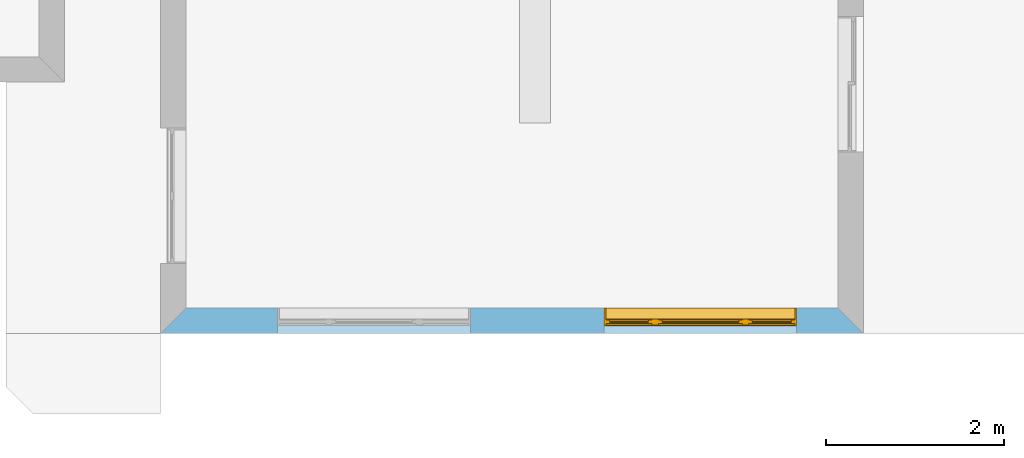
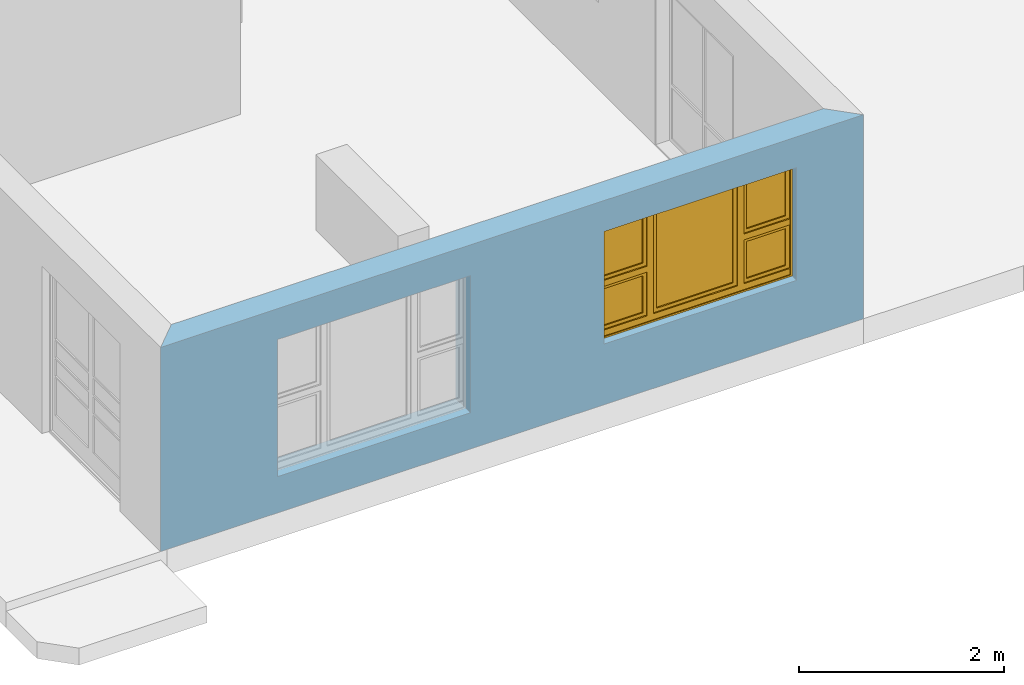
# One storey, part 5 of 15: 1 window, 2 openings, plus 1 element that does not belong to this part.
"""IFC4 building model written with IfcOpenShell, lengths in millimetres."""

from ifc_helpers import new_model, entity, si_unit, converted_unit, frame, origin_with_axes, origin_2d_with_axis, place, context, subcontext, project, spatial, line, indexed_curve, outline, extrude, clip, halfspace, polygons, source, transform, mapped, material, layer, layer_set, layer_usage, type_object, type_shapes, element, fill, save


model = new_model("IFC4")

# Units and contexts
model_context = context("Model", 3, precision=1e-05, world=origin_with_axes())
plan_context = context("Plan", 2, precision=1e-05, world=origin_2d_with_axis())
body_context = subcontext(model_context, "Body", "Model", "MODEL_VIEW")
ifc_project = project(units=[si_unit("VOLUMEUNIT", "CUBIC_METRE"), si_unit("LENGTHUNIT", "METRE", prefix="MILLI"), converted_unit("PLANEANGLEUNIT", "degree", entity("IfcReal", 0.0174532925199433), si_unit("PLANEANGLEUNIT", "RADIAN"), dimensions=[0, 0, 0, 0, 0, 0, 0]), si_unit("AREAUNIT", "SQUARE_METRE")], contexts=[model_context, plan_context])

# Site, building, storey
site_placement = place(None, origin_with_axes())
site = spatial("IfcSite", under=ifc_project, at=site_placement)
building_placement = place(site_placement, origin_with_axes())
building = spatial("IfcBuilding", under=site, at=building_placement, Name="Building")
storey_placement = place(building_placement, origin_with_axes())
storey = spatial("IfcBuildingStorey", under=building, at=storey_placement, Name="EXISTING")

# Wall, openings, window
ifc_material = material()
ifc_layer = layer(ifc_material, 285.0, Name="brick")
ifc_layer_set = layer_set([ifc_layer])
ifc_layer_usage = layer_usage(ifc_layer_set, "AXIS2", "POSITIVE", 0.0)
wall_type = type_object("IfcWallType", Name="285mm Wall", PredefinedType="STANDARD", material=ifc_layer_set)
wall_placement = place(storey_placement, frame((5594.11907196045, -4518.33248138428, 0.0), z_axis=(0.0, 0.0, 1.0), x_axis=(0.999999999999993, 1.19209282445353e-07, 0.0)))
wall = element("IfcWall", 1, at=wall_placement, inside=storey, type_object=wall_type, material=ifc_layer_usage, Name="Wall", context=body_context, shape_type="Clipping", body=[
    clip(clip(extrude(outline(indexed_curve([(0.0, 0.0), (0.0, 285.0), (7900.00095608862, 285.0), (7900.00095608862, 0.0), (0.0, 0.0)], self_intersect=False)), origin_with_axes(), (0.0, 0.0, 1.0), 2425.00019073486), halfspace(frame((7900.00104904175, 0.0, 0.0), z_axis=(0.707107067108154, 0.707106471061707, 0.0), x_axis=(0.707106483163256, -0.707107079209714, 0.0)), False)), halfspace(frame((0.0, 0.0, 0.0), z_axis=(-0.707106471061707, 0.707107067108154, 0.0), x_axis=(0.707107079209714, 0.707106483163256, 0.0)), False)),
])
shared_shape_1 = source(origin_with_axes(), body_context, "Body", "SweptSolid", [
    extrude(outline(indexed_curve([(0.0, 0.0), (2165.00024414062, 0.0), (2165.00024414062, 1629.99987792969), (0.0, 1629.99987792969)], segments=[line(1, 2, 3, 4, 1)])), frame((-1.04308121251506e-07, -600.0, 0.0), z_axis=(0.0, -1.0, 0.0), x_axis=(1.0, 0.0, 0.0)), (0.0, 0.0, -1.0), 1200.0),
])
opening_1_placement = place(wall_placement, frame((3482.00082778931, 136.111021041866, 430.000007152557), z_axis=(0.0, 0.0, 1.0), x_axis=(-0.999999999999989, 1.50995802528085e-07, 0.0)))
element("IfcOpeningElement", 2, at=opening_1_placement, cuts=wall, Name="Opening", PredefinedType="OPENING", context=body_context, shape_type="MappedRepresentation", body=[
    mapped(shared_shape_1, transform((0.0, 0.0, 0.0), x_axis=(1.0, 0.0, 0.0), y_axis=(0.0, 1.0, 0.0), z_axis=(0.0, 0.0, 1.0), scale=1.0)),
])
shared_shape_2 = source(origin_with_axes(), body_context, "Body", "SweptSolid", [
    extrude(outline(indexed_curve([(0.0, 0.0), (2165.00048828125, 0.0), (2165.00048828125, 1340.00048828125), (0.0, 1340.00048828125)], segments=[line(1, 2, 3, 4, 1)])), frame((-5.96046390910487e-07, -600.0, 0.0), z_axis=(0.0, -1.0, 0.0), x_axis=(1.0, 0.0, 0.0)), (0.0, 0.0, -1.0), 1200.0),
])
opening_2_placement = place(wall_placement, frame((7150.00581741333, 136.111021041866, 719.999313354492), z_axis=(0.0, 0.0, 1.0), x_axis=(-0.999999999999989, 1.50995802528085e-07, 0.0)))
opening_2 = element("IfcOpeningElement", 3, at=opening_2_placement, cuts=wall, PredefinedType="OPENING", context=body_context, shape_type="MappedRepresentation", body=[
    mapped(shared_shape_2, transform((0.0, 0.0, 0.0), x_axis=(1.0, 0.0, 0.0), y_axis=(0.0, 1.0, 0.0), z_axis=(0.0, 0.0, 1.0), scale=1.0)),
])
window_type = type_object("IfcWindowType", Name="Ex.2165x1340", PartitioningType="NOTDEFINED", PredefinedType="WINDOW")
shared_shape_3 = source(origin_with_axes(), body_context, "Body", "Tessellation", [
    polygons([(2165.00024414062, -148.888916015625, 0.0), (2165.00024414062, -148.888916015625, 19.999979019165), (0.000119209282274824, -148.888977050781, 0.0), (0.000119209282274824, -148.888977050781, 19.999979019165), (2165.00024414062, 51.1110572814941, 0.0), (2165.00024414062, 51.1110572814941, 19.999979019165), (0.000119209282274824, 51.1110000610352, 0.0), (0.000119209282274824, 51.1110000610352, 19.999979019165), (2165.00024414062, -148.888916015625, 1320.00048828125), (2165.00024414062, -148.888916015625, 1340.00048828125), (0.000119209282274824, -148.888977050781, 1320.00048828125), (0.000119209282274824, -148.888977050781, 1340.00048828125), (2165.00024414062, 51.1110572814941, 1320.00048828125), (2165.00024414062, 51.1110572814941, 1340.00048828125), (0.000119209282274824, 51.1110000610352, 1320.00048828125), (0.000119209282274824, 51.1110000610352, 1340.00048828125), (0.000119209282274824, -148.888916015625, 19.9999198913574), (19.9998607635498, -148.888916015625, 19.9999198913574), (-0.000357627839548513, -148.888977050781, 1340.00036621094), (19.9996223449707, -148.888977050781, 1340.00036621094), (0.000119209282274824, 51.1110572814941, 19.9999198913574), (19.9998607635498, 51.1110572814941, 19.9999198913574), (-0.000596046389546245, 51.1110000610352, 1340.00036621094), (19.9996223449707, 51.1110000610352, 1340.00036621094), (2145.00024414062, -148.888916015625, 19.9999198913574), (2165.00024414062, -148.888916015625, 19.9999198913574), (2144.99975585938, -148.888977050781, 1340.00036621094), (2164.99975585938, -148.888977050781, 1340.00036621094), (2145.00024414062, 51.1110572814941, 19.9999198913574), (2165.00024414062, 51.1110572814941, 19.9999198913574), (2144.99975585938, 51.1110000610352, 1340.00036621094), (2164.99975585938, 51.1110000610352, 1340.00036621094), (1554.99975585938, -28.8889198303223, 19.9999198913574), (1624.99987792969, -28.8889198303223, 19.9999198913574), (1554.99951171875, -28.8889198303223, 1340.00048828125), (1624.99938964844, -28.8889198303223, 1340.00048828125), (1554.99975585938, 41.1110687255859, 19.9999198913574), (1624.99987792969, 41.1110687255859, 19.9999198913574), (1554.99951171875, 41.1110076904297, 1340.00048828125), (1624.99938964844, 41.1110687255859, 1340.00048828125), (539.999938964844, -28.8889198303223, 19.9999198913574), (609.999633789062, -28.8889198303223, 19.9999198913574), (539.999450683594, -28.8889198303223, 1340.00048828125), (609.999633789062, -28.8889198303223, 1340.00048828125), (539.999938964844, 41.1110687255859, 19.9999198913574), (609.999633789062, 41.1110687255859, 19.9999198913574), (539.999450683594, 41.1110076904297, 1340.00048828125), (609.999633789062, 41.1110687255859, 1340.00048828125), (19.9998607635498, -28.8889808654785, 679.999328613281), (19.9998607635498, -28.8889808654785, 609.999877929688), (539.999938964844, -28.8889198303223, 680.0), (539.999938964844, -28.8888607025146, 610.000671386719), (19.9998607635498, 41.1109504699707, 679.999328613281), (19.9998607635498, 41.1110076904297, 609.999877929688), (539.999938964844, 41.1110687255859, 680.0), (539.999938964844, 41.1110687255859, 610.000671386719), (1624.99987792969, -28.8889808654785, 679.999328613281), (1624.99987792969, -28.8889808654785, 609.999877929688), (2144.99975585938, -28.8889198303223, 680.0), (2144.99975585938, -28.8888607025146, 610.000671386719), (1624.99987792969, 41.1109504699707, 679.999328613281), (1624.99987792969, 41.1110076904297, 609.999877929688), (2144.99975585938, 41.1110687255859, 680.0), (2144.99975585938, 41.1110687255859, 610.000671386719), (1624.99987792969, -13.8889951705933, 1319.99987792969), (1624.99987792969, -13.8889951705933, 1280.00024414062), (2144.99975585938, -13.8889360427856, 1320.00048828125), (2144.99975585938, -13.8889360427856, 1280.00073242188), (1624.99987792969, 26.1109638214111, 1319.99987792969), (1624.99987792969, 26.1109638214111, 1280.00024414062), (2144.99975585938, 26.111083984375, 1320.00048828125), (2144.99975585938, 26.111083984375, 1280.00073242188), (1624.99987792969, -13.8889951705933, 719.9990234375), (1624.99987792969, -13.8889951705933, 679.999328613281), (2144.99975585938, -13.8889360427856, 719.99951171875), (2144.99975585938, -13.8889360427856, 679.999816894531), (1624.99987792969, 26.1109638214111, 719.9990234375), (1624.99987792969, 26.1109638214111, 679.999328613281), (2144.99975585938, 26.111083984375, 719.99951171875), (2144.99975585938, 26.111083984375, 679.999816894531), (1664.99987792969, -13.8889360427856, 1280.00024414062), (1624.99987792969, -13.8889360427856, 1280.00024414062), (1664.99987792969, -13.8889360427856, 719.998779296875), (1624.99987792969, -13.8889360427856, 719.998779296875), (1664.99987792969, 26.111083984375, 1280.00024414062), (1624.99987792969, 26.111083984375, 1280.00024414062), (1664.99987792969, 26.111083984375, 719.998779296875), (1624.99987792969, 26.111083984375, 719.998779296875), (2144.99926757812, -13.8889360427856, 1280.00024414062), (2105.0, -13.8889360427856, 1280.00024414062), (2144.99877929688, -13.8889360427856, 719.998779296875), (2104.99951171875, -13.8889360427856, 719.998779296875), (2144.99926757812, 26.111083984375, 1280.00024414062), (2105.0, 26.111083984375, 1280.00024414062), (2144.99877929688, 26.111083984375, 719.998779296875), (2104.99951171875, 26.111083984375, 719.998779296875), (19.9998607635498, -13.8889951705933, 1319.99987792969), (19.9998607635498, -13.8889951705933, 1280.00024414062), (539.999938964844, -13.8889360427856, 1320.00048828125), (539.999938964844, -13.8889360427856, 1280.00073242188), (19.9998607635498, 26.1109638214111, 1319.99987792969), (19.9998607635498, 26.1109638214111, 1280.00024414062), (539.999938964844, 26.111083984375, 1320.00048828125), (539.999938964844, 26.111083984375, 1280.00073242188), (19.9998607635498, -13.8889951705933, 719.9990234375), (19.9998607635498, -13.8889951705933, 679.999328613281), (539.999938964844, -13.8889360427856, 719.99951171875), (539.999938964844, -13.8889360427856, 679.999816894531), (19.9998607635498, 26.1109638214111, 719.9990234375), (19.9998607635498, 26.1109638214111, 679.999328613281), (539.999938964844, 26.111083984375, 719.99951171875), (539.999938964844, 26.111083984375, 679.999816894531), (60.0002975463867, -13.8889360427856, 1280.00024414062), (20.000337600708, -13.8889360427856, 1280.00024414062), (59.9998207092285, -13.8889360427856, 719.998779296875), (20.000337600708, -13.8889360427856, 719.998779296875), (60.0002975463867, 26.111083984375, 1280.00024414062), (20.000337600708, 26.111083984375, 1280.00024414062), (59.9998207092285, 26.111083984375, 719.998779296875), (20.000337600708, 26.111083984375, 719.998779296875), (539.999450683594, -13.8889360427856, 1280.00024414062), (499.999603271484, -13.8889360427856, 1280.00024414062), (539.999450683594, -13.8889360427856, 719.998779296875), (499.999603271484, -13.8889360427856, 719.998779296875), (539.999450683594, 26.111083984375, 1280.00024414062), (499.999603271484, 26.111083984375, 1280.00024414062), (539.999450683594, 26.111083984375, 719.998779296875), (499.999603271484, 26.111083984375, 719.998779296875), (19.9998607635498, -28.8889808654785, 89.9991912841797), (19.9998607635498, -28.8889808654785, 19.9998016357422), (539.999938964844, -28.8889198303223, 89.9999694824219), (539.999938964844, -28.8888607025146, 20.0005760192871), (19.9998607635498, 41.1109504699707, 89.9991912841797), (19.9998607635498, 41.1110076904297, 19.9998016357422), (539.999938964844, 41.1110687255859, 90.0000305175781), (539.999938964844, 41.1110687255859, 20.0005760192871), (1624.99987792969, -28.8889808654785, 89.9991912841797), (1624.99987792969, -28.8889808654785, 19.9998016357422), (2144.99975585938, -28.8889198303223, 89.9999694824219), (2144.99975585938, -28.8888607025146, 20.0005760192871), (1624.99987792969, 41.1109504699707, 89.9991912841797), (1624.99987792969, 41.1110076904297, 19.9998016357422), (2144.99975585938, 41.1110687255859, 90.0000305175781), (2144.99975585938, 41.1110687255859, 20.0005760192871), (610.000122070312, -28.8889808654785, 89.9991912841797), (610.000122070312, -28.8889808654785, 19.9998016357422), (1554.99975585938, -28.8889198303223, 89.9999694824219), (1554.99975585938, -28.8889198303223, 20.0005760192871), (610.000122070312, 41.1109504699707, 89.9991912841797), (610.000122070312, 41.1110076904297, 19.9998016357422), (1554.99975585938, 41.1110687255859, 90.0000305175781), (1554.99975585938, 41.1110687255859, 20.0005760192871), (1624.99987792969, -13.8889951705933, 610.0), (1624.99987792969, -13.8889951705933, 570.000366210938), (2144.99975585938, -13.8889360427856, 610.000549316406), (2144.99975585938, -13.8889360427856, 570.000854492188), (1624.99987792969, 26.1109638214111, 610.0), (1624.99987792969, 26.1109638214111, 570.000366210938), (2144.99975585938, 26.111083984375, 610.000549316406), (2144.99975585938, 26.111083984375, 570.000854492188), (1624.99987792969, -13.8889951705933, 129.999694824219), (1624.99987792969, -13.8889951705933, 90.0000305175781), (2144.99975585938, -13.8889360427856, 130.000228881836), (2144.99975585938, -13.8889360427856, 90.0005645751953), (1624.99987792969, 26.1109638214111, 129.999755859375), (1624.99987792969, 26.1109638214111, 90.0000305175781), (2144.99975585938, 26.111083984375, 130.000228881836), (2144.99975585938, 26.111083984375, 90.0005645751953), (1664.99987792969, -13.8889360427856, 570.000366210938), (1624.99987792969, -13.8889360427856, 570.000366210938), (1664.99987792969, -13.8889360427856, 129.999099731445), (1624.99987792969, -13.8889360427856, 129.999145507812), (1664.99987792969, 26.111083984375, 570.000366210938), (1624.99987792969, 26.111083984375, 570.000366210938), (1664.99987792969, 26.111083984375, 129.999099731445), (1624.99987792969, 26.111083984375, 129.999145507812), (2144.99926757812, -13.8889360427856, 570.000366210938), (2105.0, -13.8889360427856, 570.000366210938), (2144.99877929688, -13.8889360427856, 129.999099731445), (2104.99951171875, -13.8889360427856, 129.999145507812), (2144.99926757812, 26.111083984375, 570.000366210938), (2105.0, 26.111083984375, 570.000366210938), (2144.99877929688, 26.111083984375, 129.999099731445), (2104.99951171875, 26.111083984375, 129.999145507812), (19.9998607635498, -13.8889951705933, 610.0), (19.9998607635498, -13.8889951705933, 570.000366210938), (539.999938964844, -13.8889360427856, 610.000549316406), (539.999938964844, -13.8889360427856, 570.000854492188), (19.9998607635498, 26.1109638214111, 610.0), (19.9998607635498, 26.1109638214111, 570.000366210938), (539.999938964844, 26.111083984375, 610.000549316406), (539.999938964844, 26.111083984375, 570.000854492188), (19.9998607635498, -13.8889951705933, 129.998611450195), (19.9998607635498, -13.8889951705933, 89.9989547729492), (539.999938964844, -13.8889360427856, 129.999145507812), (539.999938964844, -13.8889360427856, 89.9994888305664), (19.9998607635498, 26.1109638214111, 129.998672485352), (19.9998607635498, 26.1109638214111, 89.9989547729492), (539.999938964844, 26.111083984375, 129.999145507812), (539.999938964844, 26.111083984375, 89.9994888305664), (60.0002975463867, -13.8889360427856, 570.000366210938), (20.000337600708, -13.8889360427856, 570.000366210938), (59.9998207092285, -13.8889360427856, 129.999099731445), (20.000337600708, -13.8889360427856, 129.999145507812), (60.0002975463867, 26.111083984375, 570.000366210938), (20.000337600708, 26.111083984375, 570.000366210938), (59.9998207092285, 26.111083984375, 129.999099731445), (20.000337600708, 26.111083984375, 129.999145507812), (539.999450683594, -13.8889360427856, 570.000366210938), (499.999603271484, -13.8889360427856, 570.000366210938), (539.999450683594, -13.8889360427856, 129.999099731445), (499.999603271484, -13.8889360427856, 129.999145507812), (539.999450683594, 26.111083984375, 570.000366210938), (499.999603271484, 26.111083984375, 570.000366210938), (539.999450683594, 26.111083984375, 129.999099731445), (499.999603271484, 26.111083984375, 129.999145507812), (610.000122070312, -13.8889951705933, 1319.99987792969), (610.000122070312, -13.8889951705933, 1280.00024414062), (1554.99951171875, -13.8889360427856, 1320.00048828125), (1554.99951171875, -13.8889360427856, 1280.00073242188), (610.000122070312, 26.1109638214111, 1319.99987792969), (610.000122070312, 26.1109638214111, 1280.00024414062), (1554.99951171875, 26.111083984375, 1320.00048828125), (1554.99951171875, 26.111083984375, 1280.00073242188), (610.000122070312, -13.8889951705933, 129.998916625977), (610.000122070312, -13.8889951705933, 89.9992523193359), (1554.99951171875, -13.8889360427856, 129.999450683594), (1554.99951171875, -13.8889360427856, 89.9997863769531), (610.000122070312, 26.1109638214111, 129.998916625977), (610.000122070312, 26.1109638214111, 89.9992523193359), (1554.99951171875, 26.111083984375, 129.99951171875), (1554.99951171875, 26.111083984375, 89.9997863769531), (650.000549316406, -13.8889360427856, 1280.00024414062), (610.000549316406, -13.8889360427856, 1280.00024414062), (650.000061035156, -13.8889360427856, 129.999450683594), (610.000549316406, -13.8889360427856, 129.999450683594), (650.000549316406, 26.111083984375, 1280.00024414062), (610.000549316406, 26.111083984375, 1280.00024414062), (650.000061035156, 26.111083984375, 129.999450683594), (610.000549316406, 26.111083984375, 129.999450683594), (1554.99975585938, -13.8889360427856, 1280.00024414062), (1514.99975585938, -13.8889360427856, 1280.00024414062), (1554.99926757812, -13.8889360427856, 129.999389648438), (1514.99975585938, -13.8889360427856, 129.999389648438), (1554.99975585938, 26.111083984375, 1280.00024414062), (1514.99975585938, 26.111083984375, 1280.00024414062), (1554.99951171875, 26.111083984375, 129.999389648438), (1514.99975585938, 26.111083984375, 129.999389648438), (1515.00024414062, 1.11104917526245, 1280.00024414062), (650.001037597656, 1.11104917526245, 1280.00024414062), (1514.99975585938, 1.11104917526245, 129.999389648438), (650.001037597656, 1.11104917526245, 129.999450683594), (1515.00024414062, 11.1110391616821, 1280.00024414062), (650.001037597656, 11.1110982894897, 1280.00024414062), (1514.99975585938, 11.1110391616821, 129.999389648438), (650.001037597656, 11.1110982894897, 129.999450683594), (2104.99853515625, 1.11104917526245, 1280.00024414062), (1664.99963378906, 1.11104917526245, 1280.00036621094), (2104.998046875, 1.11104917526245, 719.999267578125), (1664.99938964844, 1.11104917526245, 719.999267578125), (2104.99853515625, 11.1110391616821, 1280.00024414062), (1664.99963378906, 11.1110982894897, 1280.00036621094), (2104.998046875, 11.1110391616821, 719.999267578125), (1664.99938964844, 11.1110982894897, 719.999267578125), (2104.99853515625, 1.11104917526245, 570.000244140625), (1664.99963378906, 1.11104917526245, 570.000244140625), (2104.998046875, 1.11104917526245, 130.000579833984), (1664.99938964844, 1.11104917526245, 130.000579833984), (2104.99853515625, 11.1110391616821, 570.000244140625), (1664.99963378906, 11.1110982894897, 570.000244140625), (2104.998046875, 11.1110391616821, 130.000579833984), (1664.99938964844, 11.1110982894897, 130.000579833984), (499.998657226562, 1.11104917526245, 1280.00024414062), (60.000057220459, 1.11104917526245, 1280.00036621094), (499.998657226562, 1.11104917526245, 719.999267578125), (59.9998207092285, 1.11104917526245, 719.999267578125), (499.998657226562, 11.1110391616821, 1280.00024414062), (60.000057220459, 11.1110982894897, 1280.00036621094), (499.998657226562, 11.1110391616821, 719.999267578125), (59.9998207092285, 11.1110982894897, 719.999267578125), (499.998657226562, 1.11104917526245, 570.000244140625), (60.000057220459, 1.11104917526245, 570.000244140625), (499.998413085938, 1.11104917526245, 130.000579833984), (59.9998207092285, 1.11104917526245, 130.000579833984), (499.998657226562, 11.1110391616821, 570.000244140625), (60.000057220459, 11.1110982894897, 570.000244140625), (499.998413085938, 11.1110391616821, 130.000579833984), (59.9998207092285, 11.1110982894897, 130.000579833984)], [[[1, 2, 4, 3]], [[3, 4, 8, 7]], [[7, 8, 6, 5]], [[5, 6, 2, 1]], [[3, 7, 5, 1]], [[8, 4, 2, 6]], [[9, 10, 12, 11]], [[11, 12, 16, 15]], [[15, 16, 14, 13]], [[13, 14, 10, 9]], [[11, 15, 13, 9]], [[16, 12, 10, 14]], [[17, 18, 20, 19]], [[19, 20, 24, 23]], [[23, 24, 22, 21]], [[21, 22, 18, 17]], [[19, 23, 21, 17]], [[24, 20, 18, 22]], [[25, 26, 28, 27]], [[27, 28, 32, 31]], [[31, 32, 30, 29]], [[29, 30, 26, 25]], [[27, 31, 29, 25]], [[32, 28, 26, 30]], [[33, 34, 36, 35]], [[35, 36, 40, 39]], [[39, 40, 38, 37]], [[37, 38, 34, 33]], [[35, 39, 37, 33]], [[40, 36, 34, 38]], [[41, 42, 44, 43]], [[43, 44, 48, 47]], [[47, 48, 46, 45]], [[45, 46, 42, 41]], [[43, 47, 45, 41]], [[48, 44, 42, 46]], [[49, 50, 52, 51]], [[51, 52, 56, 55]], [[55, 56, 54, 53]], [[53, 54, 50, 49]], [[51, 55, 53, 49]], [[56, 52, 50, 54]], [[57, 58, 60, 59]], [[59, 60, 64, 63]], [[63, 64, 62, 61]], [[61, 62, 58, 57]], [[59, 63, 61, 57]], [[64, 60, 58, 62]], [[65, 66, 68, 67]], [[67, 68, 72, 71]], [[71, 72, 70, 69]], [[69, 70, 66, 65]], [[67, 71, 69, 65]], [[72, 68, 66, 70]], [[73, 74, 76, 75]], [[75, 76, 80, 79]], [[79, 80, 78, 77]], [[77, 78, 74, 73]], [[75, 79, 77, 73]], [[80, 76, 74, 78]], [[81, 82, 84, 83]], [[83, 84, 88, 87]], [[87, 88, 86, 85]], [[85, 86, 82, 81]], [[83, 87, 85, 81]], [[88, 84, 82, 86]], [[89, 90, 92, 91]], [[91, 92, 96, 95]], [[95, 96, 94, 93]], [[93, 94, 90, 89]], [[91, 95, 93, 89]], [[96, 92, 90, 94]], [[97, 98, 100, 99]], [[99, 100, 104, 103]], [[103, 104, 102, 101]], [[101, 102, 98, 97]], [[99, 103, 101, 97]], [[104, 100, 98, 102]], [[105, 106, 108, 107]], [[107, 108, 112, 111]], [[111, 112, 110, 109]], [[109, 110, 106, 105]], [[107, 111, 109, 105]], [[112, 108, 106, 110]], [[113, 114, 116, 115]], [[115, 116, 120, 119]], [[119, 120, 118, 117]], [[117, 118, 114, 113]], [[115, 119, 117, 113]], [[120, 116, 114, 118]], [[121, 122, 124, 123]], [[123, 124, 128, 127]], [[127, 128, 126, 125]], [[125, 126, 122, 121]], [[123, 127, 125, 121]], [[128, 124, 122, 126]], [[129, 130, 132, 131]], [[131, 132, 136, 135]], [[135, 136, 134, 133]], [[133, 134, 130, 129]], [[131, 135, 133, 129]], [[136, 132, 130, 134]], [[137, 138, 140, 139]], [[139, 140, 144, 143]], [[143, 144, 142, 141]], [[141, 142, 138, 137]], [[139, 143, 141, 137]], [[144, 140, 138, 142]], [[145, 146, 148, 147]], [[147, 148, 152, 151]], [[151, 152, 150, 149]], [[149, 150, 146, 145]], [[147, 151, 149, 145]], [[152, 148, 146, 150]], [[153, 154, 156, 155]], [[155, 156, 160, 159]], [[159, 160, 158, 157]], [[157, 158, 154, 153]], [[155, 159, 157, 153]], [[160, 156, 154, 158]], [[161, 162, 164, 163]], [[163, 164, 168, 167]], [[167, 168, 166, 165]], [[165, 166, 162, 161]], [[163, 167, 165, 161]], [[168, 164, 162, 166]], [[169, 170, 172, 171]], [[171, 172, 176, 175]], [[175, 176, 174, 173]], [[173, 174, 170, 169]], [[171, 175, 173, 169]], [[176, 172, 170, 174]], [[177, 178, 180, 179]], [[179, 180, 184, 183]], [[183, 184, 182, 181]], [[181, 182, 178, 177]], [[179, 183, 181, 177]], [[184, 180, 178, 182]], [[185, 186, 188, 187]], [[187, 188, 192, 191]], [[191, 192, 190, 189]], [[189, 190, 186, 185]], [[187, 191, 189, 185]], [[192, 188, 186, 190]], [[193, 194, 196, 195]], [[195, 196, 200, 199]], [[199, 200, 198, 197]], [[197, 198, 194, 193]], [[195, 199, 197, 193]], [[200, 196, 194, 198]], [[201, 202, 204, 203]], [[203, 204, 208, 207]], [[207, 208, 206, 205]], [[205, 206, 202, 201]], [[203, 207, 205, 201]], [[208, 204, 202, 206]], [[209, 210, 212, 211]], [[211, 212, 216, 215]], [[215, 216, 214, 213]], [[213, 214, 210, 209]], [[211, 215, 213, 209]], [[216, 212, 210, 214]], [[217, 218, 220, 219]], [[219, 220, 224, 223]], [[223, 224, 222, 221]], [[221, 222, 218, 217]], [[219, 223, 221, 217]], [[224, 220, 218, 222]], [[225, 226, 228, 227]], [[227, 228, 232, 231]], [[231, 232, 230, 229]], [[229, 230, 226, 225]], [[227, 231, 229, 225]], [[232, 228, 226, 230]], [[233, 234, 236, 235]], [[235, 236, 240, 239]], [[239, 240, 238, 237]], [[237, 238, 234, 233]], [[235, 239, 237, 233]], [[240, 236, 234, 238]], [[241, 242, 244, 243]], [[243, 244, 248, 247]], [[247, 248, 246, 245]], [[245, 246, 242, 241]], [[243, 247, 245, 241]], [[248, 244, 242, 246]], [[249, 250, 252, 251]], [[251, 252, 256, 255]], [[255, 256, 254, 253]], [[253, 254, 250, 249]], [[251, 255, 253, 249]], [[256, 252, 250, 254]], [[257, 258, 260, 259]], [[259, 260, 264, 263]], [[263, 264, 262, 261]], [[261, 262, 258, 257]], [[259, 263, 261, 257]], [[264, 260, 258, 262]], [[265, 266, 268, 267]], [[267, 268, 272, 271]], [[271, 272, 270, 269]], [[269, 270, 266, 265]], [[267, 271, 269, 265]], [[272, 268, 266, 270]], [[273, 274, 276, 275]], [[275, 276, 280, 279]], [[279, 280, 278, 277]], [[277, 278, 274, 273]], [[275, 279, 277, 273]], [[280, 276, 274, 278]], [[281, 282, 284, 283]], [[283, 284, 288, 287]], [[287, 288, 286, 285]], [[285, 286, 282, 281]], [[283, 287, 285, 281]], [[288, 284, 282, 286]]], closed=True),
])
type_shapes(window_type, [shared_shape_3])
window_placement = place(opening_2_placement, frame((0.000460611357055996, 0.0015676028093381, 2.22044604925031e-13), z_axis=(0.0, 0.0, 1.0), x_axis=(0.999999999999993, -1.19209282445353e-07, 0.0)))
window = element("IfcWindow", 4, at=window_placement, inside=storey, type_object=window_type, Name="Window", context=body_context, shape_type="MappedRepresentation", body=[
    mapped(shared_shape_3, transform((0.0, 0.0, 0.0), x_axis=(1.0, 0.0, 0.0), y_axis=(0.0, 1.0, 0.0), z_axis=(0.0, 0.0, 1.0), scale=1.0)),
])
fill(opening_2, window)

save(model, "model.ifc")
